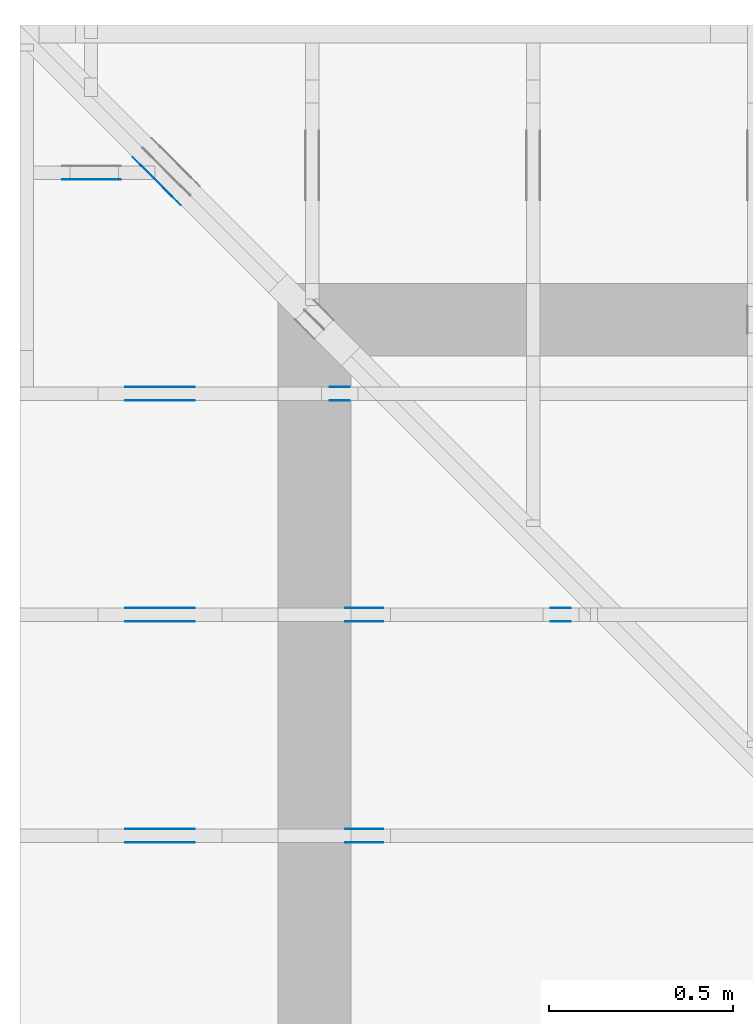
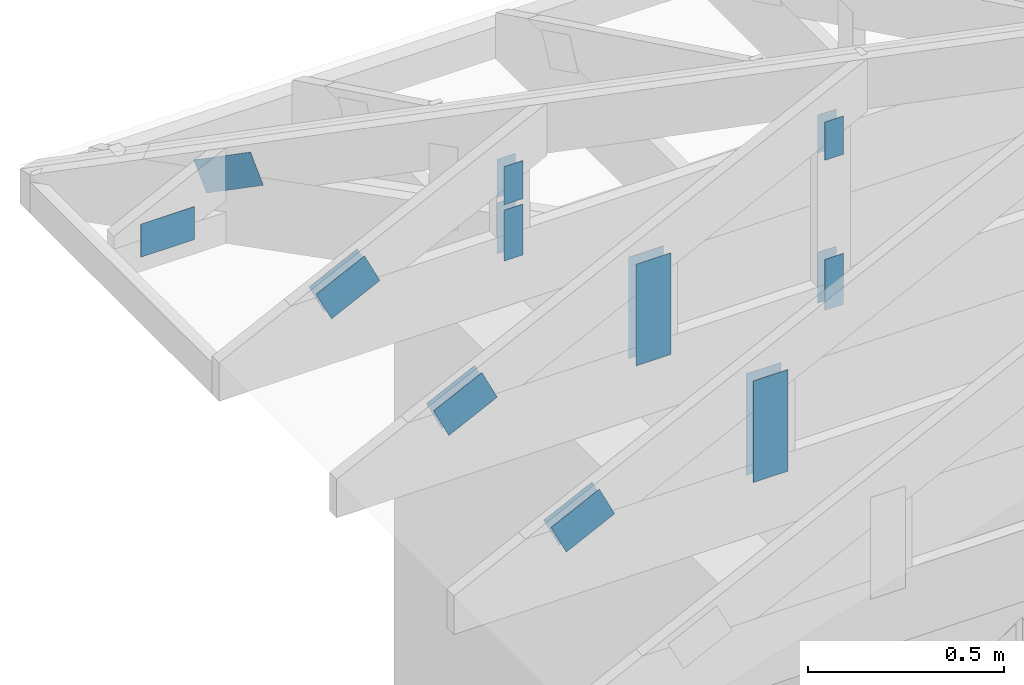
# One storey, part 89 of 159: 20 plates, 5 elements without a shape of their own.
"""IFC2X3 building model written with IfcOpenShell, lengths in millimetres."""

import ifcopenshell
import ifcopenshell.guid

model = None  # the IFC model being written
_history = None  # IfcOwnerHistory: only IFC2X3 demands one
_inside = {}  # id of a spatial element -> (the spatial element, [elements in it])
_under = {}  # id of a project, library or spatial element -> (it, [spatial elements below it])
_declared = {}  # id of a project -> (the project, [libraries it declares])
_typed = {}  # id of a type object -> (the type object, [elements of that type])
_made_of = {}  # id of a material, layer set ... -> (it, [elements and type objects made of it])


def new_model(schema):
    """Start an empty IFC model of exactly this schema.

    Asked for "IFC4X3", IfcOpenShell would pick the latest addendum, in which some entities
    have other attributes; the version numbers below select the first issue.
    IFC2X3 requires an IfcOwnerHistory on every rooted entity: one is made here for all.
    """
    global model, _history
    if schema == "IFC4X3":
        model = ifcopenshell.file(schema_version=(4, 3, 0, 0))
    else:
        model = ifcopenshell.file(schema=schema)
    _inside.clear()
    _under.clear()
    _declared.clear()
    _typed.clear()
    _made_of.clear()
    _history = None
    if model.schema == "IFC2X3":
        org = make("IfcOrganization", Name="unknown")
        user = make(
            "IfcPersonAndOrganization",
            ThePerson=make("IfcPerson", FamilyName="unknown"),
            TheOrganization=org,
        )
        app = make(
            "IfcApplication",
            ApplicationDeveloper=org,
            Version="unknown",
            ApplicationFullName="unknown",
            ApplicationIdentifier="unknown",
        )
        _history = make(
            "IfcOwnerHistory",
            OwningUser=user,
            OwningApplication=app,
            ChangeAction="ADDED",
            CreationDate=0,
        )
    return model


def make(cls, **values):
    """One entity of the class cls with the attributes given. An attribute that is None is left unset."""
    return model.create_entity(
        cls, **{name: value for name, value in values.items() if value is not None}
    )


def rooted(cls, **values):
    """An entity with a GlobalId (a new one), such as an element, a storey or a relation."""
    return make(cls, GlobalId=ifcopenshell.guid.new(), OwnerHistory=_history, **values)


def si_unit(unit_type, name, prefix=None):
    """IfcSIUnit, for example si_unit("LENGTHUNIT", "METRE", prefix="MILLI")."""
    return make("IfcSIUnit", UnitType=unit_type, Prefix=prefix, Name=name)


def assignment(units):
    """IfcUnitAssignment: the units of a project."""
    return None if units is None else make("IfcUnitAssignment", Units=units)


def point(xyz):
    """IfcCartesianPoint."""
    return None if xyz is None else make("IfcCartesianPoint", Coordinates=xyz)


def direction(xyz):
    """IfcDirection."""
    return None if xyz is None else make("IfcDirection", DirectionRatios=xyz)


def frame(location, z_axis=None, x_axis=None):
    """IfcAxis2Placement3D, a coordinate frame: its origin and axes. An axis left out is left unset."""
    return make(
        "IfcAxis2Placement3D",
        Location=point(location),
        Axis=direction(z_axis),
        RefDirection=direction(x_axis),
    )


def frame_2d(location, x_axis=None):
    """IfcAxis2Placement2D, a coordinate frame in the plane: its origin and x axis."""
    return make(
        "IfcAxis2Placement2D", Location=point(location), RefDirection=direction(x_axis)
    )


def origin():
    """The frame at (0, 0, 0) with its axes left unset."""
    return frame((0.0, 0.0, 0.0))


def origin_with_axes():
    """The frame at (0, 0, 0) with the z axis (0, 0, 1) and the x axis (1, 0, 0) written out."""
    return frame((0.0, 0.0, 0.0), z_axis=(0.0, 0.0, 1.0), x_axis=(1.0, 0.0, 0.0))


def origin_2d():
    """The frame at (0, 0) in the plane with its x axis left unset."""
    return frame_2d((0.0, 0.0))


def place(relative_to, where):
    """IfcLocalPlacement: puts the frame where relative to a parent placement (None: the world)."""
    return make(
        "IfcLocalPlacement", PlacementRelTo=relative_to, RelativePlacement=where
    )


def context(
    kind, dimensions, precision=None, world=None, true_north=None, identifier=None
):
    """IfcGeometricRepresentationContext, for example the 3D "Model" context."""
    return make(
        "IfcGeometricRepresentationContext",
        ContextIdentifier=identifier,
        ContextType=kind,
        CoordinateSpaceDimension=dimensions,
        Precision=precision,
        WorldCoordinateSystem=world,
        TrueNorth=true_north,
    )


def project(units=None, contexts=None):
    """IfcProject with its units and contexts."""
    return rooted(
        "IfcProject",
        Name="project",
        RepresentationContexts=contexts,
        UnitsInContext=assignment(units),
    )


def spatial(cls, under=None, at=None, **own):
    """A site, building, storey or space (cls), placed at a placement, below another one or the project."""
    s = rooted(cls, ObjectPlacement=at, **own)
    if under is not None:
        _under.setdefault(under.id(), (under, []))[1].append(s)
    return s


def faces_of(points, faces, orient=None, outer=None):
    """IfcFace entities. A face is a list of loops; a loop is a list of indices into points, from 0.

    orient and outer hold one flag for each loop. By default every Orientation is true, the
    first loop of a face is its IfcFaceOuterBound and the others are IfcFaceBound.
    """
    made = []
    for i, loops in enumerate(faces):
        bounds = []
        for j, loop in enumerate(loops):
            is_outer = j == 0 if outer is None else outer[i][j]
            bounds.append(
                make(
                    "IfcFaceOuterBound" if is_outer else "IfcFaceBound",
                    Bound=make("IfcPolyLoop", Polygon=[points[k] for k in loop]),
                    Orientation=True if orient is None else orient[i][j],
                )
            )
        made.append(make("IfcFace", Bounds=bounds))
    return made


def faceted_brep(points, faces, orient=None, outer=None, voids=None):
    """IfcFacetedBrep: a solid bounded by flat faces; with voids (closed shells), ...WithVoids."""
    shared = [point(p) for p in points]
    hull = make("IfcClosedShell", CfsFaces=faces_of(shared, faces, orient, outer))
    if voids is None:
        return make("IfcFacetedBrep", Outer=hull)
    return make(
        "IfcFacetedBrepWithVoids",
        Outer=hull,
        Voids=[
            make(cls, CfsFaces=faces_of(shared, fs, o, b)) for cls, fs, o, b in voids
        ],
    )


def shape(context_of_items, identifier, shape_type, items):
    """IfcShapeRepresentation: the items that make up one representation, for example the "Body"."""
    return make(
        "IfcShapeRepresentation",
        ContextOfItems=context_of_items,
        RepresentationIdentifier=identifier,
        RepresentationType=shape_type,
        Items=items,
    )


def made_of(thing, what):
    """Note that an element or type object is made of a material, layer set ...; save() writes the relation."""
    if what is not None:
        _made_of.setdefault(what.id(), (what, []))[1].append(thing)
    return thing


def element(
    cls,
    number,
    at=None,
    inside=None,
    cuts=None,
    type_object=None,
    material=None,
    context=None,
    identifier="Body",
    shape_type=None,
    held_by="IfcProductDefinitionShape",
    body=None,
    shapes=None,
    **own,
):
    """One element of the class cls, such as IfcWall. Its Tag is "e" and its number.

    at: its placement. inside: the storey or other place that contains it. cuts: it is an
    opening in that element (IfcRelVoidsElement). A single representation is given by context,
    identifier, shape_type and body (its items); several are given by shapes. held_by: the class
    of the entity that holds the representations. save() writes the other relations.
    """
    e = rooted(cls, Tag="e%d" % number, ObjectPlacement=at, **own)
    if body is not None:
        shapes = [shape(context, identifier, shape_type, body)]
    if shapes is not None:
        e.Representation = make(held_by, Representations=shapes)
    if inside is not None:
        _inside.setdefault(inside.id(), (inside, []))[1].append(e)
    if cuts is not None:
        rooted(
            "IfcRelVoidsElement", RelatingBuildingElement=cuts, RelatedOpeningElement=e
        )
    if type_object is not None:
        _typed.setdefault(type_object.id(), (type_object, []))[1].append(e)
    return made_of(e, material)


def aggregate(whole, parts):
    """IfcRelAggregates: a whole, such as a stair, and the parts it consists of."""
    return rooted("IfcRelAggregates", RelatingObject=whole, RelatedObjects=parts)


def save(model, path):
    """Write the relations noted so far, then the file.

    IfcRelAggregates (storeys below a building ...), IfcRelContainedInSpatialStructure (elements
    in a storey), IfcRelDefinesByType, IfcRelAssociatesMaterial and IfcRelDeclares: one each for
    every whole, place, type object, material and project.
    """
    for whole, parts in _under.values():
        aggregate(whole, parts)
    for where, things in _inside.values():
        rooted(
            "IfcRelContainedInSpatialStructure",
            RelatedElements=things,
            RelatingStructure=where,
        )
    for kind, things in _typed.values():
        rooted("IfcRelDefinesByType", RelatedObjects=things, RelatingType=kind)
    for what, things in _made_of.values():
        rooted("IfcRelAssociatesMaterial", RelatedObjects=things, RelatingMaterial=what)
    for by, libraries in _declared.values():
        rooted("IfcRelDeclares", RelatingContext=by, RelatedDefinitions=libraries)
    model.write(path)


model = new_model("IFC2X3")

# Units and contexts
model_context = context("Model", 3, precision=1e-05, world=origin())
plan_context = context("Plan", 2, precision=1e-05, world=origin_2d())
ifc_project = project(units=[si_unit("LENGTHUNIT", "METRE", prefix="MILLI"), si_unit("AREAUNIT", "SQUARE_METRE"), si_unit("VOLUMEUNIT", "CUBIC_METRE"), si_unit("SOLIDANGLEUNIT", "STERADIAN"), si_unit("PLANEANGLEUNIT", "RADIAN"), si_unit("MASSUNIT", "GRAM"), si_unit("TIMEUNIT", "SECOND"), si_unit("THERMODYNAMICTEMPERATUREUNIT", "DEGREE_CELSIUS"), si_unit("LUMINOUSINTENSITYUNIT", "LUMEN")], contexts=[model_context, plan_context])

# Site, building, storey
site_placement = place(None, origin_with_axes())
site = spatial("IfcSite", under=ifc_project, at=site_placement, CompositionType="ELEMENT")
building_placement = place(site_placement, origin_with_axes())
building = spatial("IfcBuilding", under=site, at=building_placement, Name="Plan 1", CompositionType="ELEMENT")
storey_placement = place(building_placement, origin_with_axes())
storey = spatial("IfcBuildingStorey", under=building, at=storey_placement, Name="Etasje 1", CompositionType="ELEMENT", Elevation=0.0)

# Assembly, plate
assembly_1_placement = place(storey_placement, frame((-664.000000000003, 9281.993668449246, 1.1021457184401395e-15), z_axis=(0.0, -1.0, 6.123031769111886e-17), x_axis=(1.0, 0.0, 0.0)))
assembly_1 = element("IfcElementAssembly", 1, at=assembly_1_placement, inside=storey, Name="S9 (107)", AssemblyPlace="FACTORY", PredefinedType="TRUSS")
plate_1_placement = place(assembly_1_placement, frame((237.78413391113284, 148.90464782714844, 0.0), z_axis=(0.0, 0.0, 1.0), x_axis=(-1.0, 1.2246063538223773e-16, 0.0)))
plate_1 = element("IfcPlate", 2, at=plate_1_placement, Name="GNT100S 103x159", context=model_context, shape_type="Brep", body=[
    faceted_brep([(159.0, 103.0, 1.0), (0.0, 103.0, 1.0), (2.842170943040401e-14, 0.0, 1.0), (159.0, 0.0, 1.0), (0.0, 103.0, 0.0), (159.0, 103.0, 1.9471241025775798e-14), (159.0, 2.842170943040401e-14, 1.9471241025775798e-14), (2.842170943040401e-14, 2.842170943040401e-14, 3.4805405954966126e-30), (159.00000085986846, 8.447997602500227e-14, 1.7883454204442307e-30), (159.00000085986846, 8.454120634269339e-14, 1.0), (8.59868492852911e-07, 1.1374806788135708e-13, 1.0), (8.59868492852911e-07, 1.1368683756366597e-13, 9.671333203439804e-39), (159.00000085986846, 103.00000000000011, 0.0), (159.00000085986846, 103.00000000000011, 1.0), (159.00000085986846, 1.1368683772161603e-13, 1.0), (159.00000085986846, 1.1368683772161603e-13, 0.0), (8.598684644312016e-07, 103.00000000000011, 0.0), (8.598684644312016e-07, 103.00000000000011, 1.0), (159.00000085986846, 103.0000000000001, 1.0), (159.00000085986846, 103.0000000000001, -7.888609052210118e-31), (8.59868492852911e-07, 1.1368683772161602e-13, 0.0), (8.598684929141413e-07, 1.1368683772161602e-13, 1.0), (8.598685055275868e-07, 103.00000000000011, 1.0), (8.598685054663564e-07, 103.00000000000011, -2.512595570956075e-30)], [[[0, 1, 2, 3]], [[4, 5, 6, 7]], [[8, 9, 10, 11]], [[12, 13, 14, 15]], [[16, 17, 18, 19]], [[20, 21, 22, 23]]]),
])
aggregate(assembly_1, [plate_1])

# Assembly, plates
assembly_2_placement = place(storey_placement, frame((-700.000000000007, 8681.993668449246, 1.1021457184401395e-15), z_axis=(0.0, -1.0, 6.123031769111886e-17), x_axis=(1.0, 0.0, 0.0)))
assembly_2 = element("IfcElementAssembly", 3, at=assembly_2_placement, inside=storey, Name="S8 (16)", AssemblyPlace="FACTORY", PredefinedType="TRUSS")
plate_2_placement = place(assembly_2_placement, frame((331.1100183702398, 141.86159042510408, 0.0), z_axis=(0.0, 0.0, 1.0), x_axis=(0.898794046299167, 0.4383711467890774, 0.0)))
plate_2 = element("IfcPlate", 4, at=plate_2_placement, Name="GNT100S 103x159", context=model_context, shape_type="Brep", body=[
    faceted_brep([(158.99998918476712, 103.00001264929412, 1.0), (1.0551442699124891e-05, 103.00001264929412, 1.0), (3.1694610242993804e-06, 1.220379553501516e-05, 1.0), (159.00000923180295, 1.220379553501516e-05, 1.0), (1.0551442699124891e-05, 103.00001264929412, 1.2921363771341076e-21), (158.99998918476712, 103.00001264929412, 1.947123970133551e-14), (159.00000923180295, 0.0, 1.9471242156308252e-14), (3.1694610242993804e-06, 0.0, 3.8813421085494012e-22), (159.00000000000006, 1.1149114128908619e-05, 4.8075085841285717e-32), (159.00000000000006, 1.114911412896985e-05, 1.0), (5.684341886080801e-14, 1.1149114158176711e-05, 1.0), (5.684341886080801e-14, 1.114911415811548e-05, 0.0), (159.00000000000006, 103.00001114911416, 0.0), (159.00000000000006, 103.00001114911416, 1.0), (159.00000000000006, 1.1149114129693771e-05, 1.0), (159.00000000000006, 1.1149114129693771e-05, 0.0), (0.0, 103.00001114911416, 0.0), (-3.7491518045553436e-33, 103.00001114911416, 1.0), (159.00000000000006, 103.00001114911414, 1.0), (159.00000000000006, 103.00001114911414, -7.888609052210118e-31), (5.68434214278835e-14, 1.114911415811548e-05, -1.5718284790124237e-37), (5.690465174557462e-14, 1.114911415811548e-05, 1.0), (2.3776908575388665e-14, 103.00001114911416, 1.0), (2.3715678257697546e-14, 103.00001114911416, -1.4521185139791808e-30)], [[[0, 1, 2, 3]], [[4, 5, 6, 7]], [[8, 9, 10, 11]], [[12, 13, 14, 15]], [[16, 17, 18, 19]], [[20, 21, 22, 23]]]),
])
plate_3_placement = place(assembly_2_placement, frame((331.1100183702398, 141.86159042510408, -37.00000000000001), z_axis=(0.0, 0.0, 1.0), x_axis=(0.898794046299167, 0.4383711467890774, 0.0)))
plate_3 = element("IfcPlate", 5, at=plate_3_placement, Name="GNT100S 103x159", context=model_context, shape_type="Brep", body=[
    faceted_brep([(158.99998918476712, 103.00001264929412, 1.0), (1.0551442699124891e-05, 103.00001264929412, 1.0), (3.1694610242993804e-06, 1.220379553501516e-05, 1.0), (159.00000923180295, 1.220379553501516e-05, 1.0), (1.0551442699124891e-05, 103.00001264929412, 1.2921363771341076e-21), (158.99998918476712, 103.00001264929412, 1.947123970133551e-14), (159.00000923180295, 0.0, 1.9471242156308252e-14), (3.1694610242993804e-06, 0.0, 3.8813421085494012e-22), (159.00000000000006, 1.1149114128908619e-05, 4.8075085841285717e-32), (159.00000000000006, 1.114911412896985e-05, 1.0), (5.684341886080801e-14, 1.1149114158176711e-05, 1.0), (5.684341886080801e-14, 1.114911415811548e-05, 0.0), (159.00000000000006, 103.00001114911416, 0.0), (159.00000000000006, 103.00001114911416, 1.0), (159.00000000000006, 1.1149114129693771e-05, 1.0), (159.00000000000006, 1.1149114129693771e-05, 0.0), (0.0, 103.00001114911416, 0.0), (-3.7491518045553436e-33, 103.00001114911416, 1.0), (159.00000000000006, 103.00001114911414, 1.0), (159.00000000000006, 103.00001114911414, -7.888609052210118e-31), (5.68434214278835e-14, 1.114911415811548e-05, -1.5718284790124237e-37), (5.690465174557462e-14, 1.114911415811548e-05, 1.0), (2.3776908575388665e-14, 103.00001114911416, 1.0), (2.3715678257697546e-14, 103.00001114911416, -1.4521185139791808e-30)], [[[0, 1, 2, 3]], [[4, 5, 6, 7]], [[8, 9, 10, 11]], [[12, 13, 14, 15]], [[16, 17, 18, 19]], [[20, 21, 22, 23]]]),
])
plate_4_placement = place(assembly_2_placement, frame((840.5946433071217, 438.23297119140625, 0.0), z_axis=(0.0, 0.0, 1.0), x_axis=(6.123031769111886e-17, -1.0, 0.0)))
plate_4 = element("IfcPlate", 6, at=plate_4_placement, Name="GNT100S 55x119", context=model_context, shape_type="Brep", body=[
    faceted_brep([(119.0, 55.000022220222036, 1.0), (0.0, 55.000022220222036, 1.0), (0.0, 2.2220222035684856e-05, 1.0), (119.0, 2.2220222035684856e-05, 1.0), (0.0, 55.000022220222036, 0.0), (119.0, 55.000022220222036, 1.457281561048629e-14), (119.0, 2.2220222035684856e-05, 1.457281561048629e-14), (0.0, 2.2220222035684856e-05, 0.0), (119.00001088225764, -2.1859225414701712e-14, 1.3384473166239653e-30), (119.00001088225764, -2.1797995097010593e-14, 1.0), (1.088225764078743e-05, 6.122831871884123e-17, 1.0), (1.088225764078743e-05, -1.99897227762606e-21, 1.223977076147831e-37), (119.00001088225764, 55.0, 0.0), (119.00001088225764, 55.0, 1.0), (119.00001088225764, 0.0, 1.0), (119.00001088225764, 0.0, 0.0), (1.088225764078743e-05, 55.0, 0.0), (1.088225764078743e-05, 55.0, 1.0), (119.00001088225764, 54.99999999999999, 1.0), (119.00001088225764, 54.99999999999999, -3.944304526105059e-31), (1.088225764078743e-05, 0.0, 0.0), (1.088225764084866e-05, -7.498303609110687e-33, 1.0), (1.0882257647583995e-05, 55.0, 1.0), (1.0882257647522764e-05, 55.0, -4.124066764605687e-31)], [[[0, 1, 2, 3]], [[4, 5, 6, 7]], [[8, 9, 10, 11]], [[12, 13, 14, 15]], [[16, 17, 18, 19]], [[20, 21, 22, 23]]]),
])
plate_5_placement = place(assembly_2_placement, frame((840.5946433071217, 438.23297119140625, -37.0), z_axis=(0.0, 0.0, 1.0), x_axis=(6.123031769111886e-17, -1.0, 0.0)))
plate_5 = element("IfcPlate", 7, at=plate_5_placement, Name="GNT100S 55x119", context=model_context, shape_type="Brep", body=[
    faceted_brep([(119.0, 55.000022220222036, 1.0), (0.0, 55.000022220222036, 1.0), (0.0, 2.2220222035684856e-05, 1.0), (119.0, 2.2220222035684856e-05, 1.0), (0.0, 55.000022220222036, 0.0), (119.0, 55.000022220222036, 1.457281561048629e-14), (119.0, 2.2220222035684856e-05, 1.457281561048629e-14), (0.0, 2.2220222035684856e-05, 0.0), (119.00001088225764, -2.1859225414701712e-14, 1.3384473166239653e-30), (119.00001088225764, -2.1797995097010593e-14, 1.0), (1.088225764078743e-05, 6.122831871884123e-17, 1.0), (1.088225764078743e-05, -1.99897227762606e-21, 1.223977076147831e-37), (119.00001088225764, 55.0, 0.0), (119.00001088225764, 55.0, 1.0), (119.00001088225764, 0.0, 1.0), (119.00001088225764, 0.0, 0.0), (1.088225764078743e-05, 55.0, 0.0), (1.088225764078743e-05, 55.0, 1.0), (119.00001088225764, 54.99999999999999, 1.0), (119.00001088225764, 54.99999999999999, -3.944304526105059e-31), (1.088225764078743e-05, 0.0, 0.0), (1.088225764084866e-05, -7.498303609110687e-33, 1.0), (1.0882257647583995e-05, 55.0, 1.0), (1.0882257647522764e-05, 55.0, -4.124066764605687e-31)], [[[0, 1, 2, 3]], [[4, 5, 6, 7]], [[8, 9, 10, 11]], [[12, 13, 14, 15]], [[16, 17, 18, 19]], [[20, 21, 22, 23]]]),
])
plate_6_placement = place(assembly_2_placement, frame((895.5946655273438, 143.5, 0.0), z_axis=(0.0, 0.0, 1.0), x_axis=(6.123031769111886e-17, 1.0, 0.0)))
plate_6 = element("IfcPlate", 8, at=plate_6_placement, Name="GNT100S 55x159", context=model_context, shape_type="Brep", body=[
    faceted_brep([(159.0, 55.0, 1.0), (0.0, 55.0, 1.0), (0.0, 0.0, 1.0), (159.0, 0.0, 1.0), (0.0, 55.0, 0.0), (159.0, 55.0, 1.9471241025775798e-14), (159.0, 0.0, 1.9471241025775798e-14), (0.0, 0.0, 0.0), (159.00000000069178, 2.22201997238578e-05, 1.788345383589592e-30), (159.00000000069178, 2.222019972391903e-05, 1.0), (6.918128292454639e-10, 2.2220199753125893e-05, 1.0), (6.918128292454639e-10, 2.2220199753064662e-05, 0.0), (159.00000000069178, 55.00002222019975, 0.0), (159.00000000069178, 55.00002222019975, 1.0), (159.00000000069178, 2.2220199753064662e-05, 1.0), (159.00000000069178, 2.2220199753064662e-05, 0.0), (6.918128292454639e-10, 55.00002222019975, 0.0), (6.918128292454639e-10, 55.00002222019975, 1.0), (159.00000000069178, 55.000022220199746, 1.0), (159.00000000069178, 55.000022220199746, -7.888609052210118e-31), (6.918128292481851e-10, 2.2220199753064662e-05, -1.6661254890463556e-37), (6.918128904785028e-10, 2.2220199753064662e-05, 1.0), (6.918196258134488e-10, 55.00002222019975, 1.0), (6.918195645831311e-10, 55.00002222019975, -4.124068651136367e-31)], [[[0, 1, 2, 3]], [[4, 5, 6, 7]], [[8, 9, 10, 11]], [[12, 13, 14, 15]], [[16, 17, 18, 19]], [[20, 21, 22, 23]]]),
])
plate_7_placement = place(assembly_2_placement, frame((895.5946655273438, 143.5, -37.0), z_axis=(0.0, 0.0, 1.0), x_axis=(6.123031769111886e-17, 1.0, 0.0)))
plate_7 = element("IfcPlate", 9, at=plate_7_placement, Name="GNT100S 55x159", context=model_context, shape_type="Brep", body=[
    faceted_brep([(159.0, 55.0, 1.0), (0.0, 55.0, 1.0), (0.0, 0.0, 1.0), (159.0, 0.0, 1.0), (0.0, 55.0, 0.0), (159.0, 55.0, 1.9471241025775798e-14), (159.0, 0.0, 1.9471241025775798e-14), (0.0, 0.0, 0.0), (159.00000000069178, 2.22201997238578e-05, 1.788345383589592e-30), (159.00000000069178, 2.222019972391903e-05, 1.0), (6.918128292454639e-10, 2.2220199753125893e-05, 1.0), (6.918128292454639e-10, 2.2220199753064662e-05, 0.0), (159.00000000069178, 55.00002222019975, 0.0), (159.00000000069178, 55.00002222019975, 1.0), (159.00000000069178, 2.2220199753064662e-05, 1.0), (159.00000000069178, 2.2220199753064662e-05, 0.0), (6.918128292454639e-10, 55.00002222019975, 0.0), (6.918128292454639e-10, 55.00002222019975, 1.0), (159.00000000069178, 55.000022220199746, 1.0), (159.00000000069178, 55.000022220199746, -7.888609052210118e-31), (6.918128292481851e-10, 2.2220199753064662e-05, -1.6661254890463556e-37), (6.918128904785028e-10, 2.2220199753064662e-05, 1.0), (6.918196258134488e-10, 55.00002222019975, 1.0), (6.918195645831311e-10, 55.00002222019975, -4.124068651136367e-31)], [[[0, 1, 2, 3]], [[4, 5, 6, 7]], [[8, 9, 10, 11]], [[12, 13, 14, 15]], [[16, 17, 18, 19]], [[20, 21, 22, 23]]]),
])
aggregate(assembly_2, [plate_2, plate_3, plate_4, plate_5, plate_6, plate_7])

assembly_3_placement = place(storey_placement, frame((-700.000000000007, 8081.993668449246, 1.1021457184401395e-15), z_axis=(0.0, -1.0, 6.123031769111886e-17), x_axis=(1.0, 0.0, 0.0)))
assembly_3 = element("IfcElementAssembly", 10, at=assembly_3_placement, inside=storey, Name="S7 (14)", AssemblyPlace="FACTORY", PredefinedType="TRUSS")
plate_8_placement = place(assembly_3_placement, frame((1440.5946044921875, 730.8725134480499, 0.0), z_axis=(0.0, 0.0, 1.0), x_axis=(6.123031769111886e-17, -1.0, 0.0)))
plate_8 = element("IfcPlate", 11, at=plate_8_placement, Name="GNT100S 55x119", context=model_context, shape_type="Brep", body=[
    faceted_brep([(119.00001588945611, 55.0, 1.0), (1.588945610819792e-05, 55.0, 1.0), (1.588945610819792e-05, 0.0, 1.0), (119.00001588945611, 0.0, 1.0), (1.588945610819792e-05, 55.0, 1.9458328908880954e-21), (119.00001588945611, 55.0, 1.457281755631918e-14), (119.00001588945611, 0.0, 1.457281755631918e-14), (1.588945610819792e-05, 0.0, 1.9458328908880954e-21), (119.0, 3.881493964942413e-05, 1.338447208185253e-30), (119.0, 3.881493964948536e-05, 1.0), (1.1247455413666031e-32, 3.8814939671344585e-05, 1.0), (0.0, 3.8814939671283355e-05, 0.0), (119.0, 55.00003881493967, 0.0), (119.0, 55.00003881493967, 1.0), (119.0, 3.8814939671283355e-05, 1.0), (119.0, 3.8814939671283355e-05, 0.0), (0.0, 55.00003881493967, 0.0), (-3.7491518045553436e-33, 55.00003881493967, 1.0), (119.0, 55.000038814939664, 1.0), (119.0, 55.000038814939664, -3.944304526105059e-31), (4.753302174468585e-21, 3.8814939671283355e-05, -2.9104620222459757e-37), (6.123507099329333e-17, 3.8814939671283355e-05, 1.0), (6.796570017016369e-15, 55.00003881493967, 1.0), (6.73533969932525e-15, 55.00003881493967, -4.1240698954729e-31)], [[[0, 1, 2, 3]], [[4, 5, 6, 7]], [[8, 9, 10, 11]], [[12, 13, 14, 15]], [[16, 17, 18, 19]], [[20, 21, 22, 23]]]),
])
plate_9_placement = place(assembly_3_placement, frame((1440.5946044921875, 730.8725134480499, -37.0), z_axis=(0.0, 0.0, 1.0), x_axis=(6.123031769111886e-17, -1.0, 0.0)))
plate_9 = element("IfcPlate", 12, at=plate_9_placement, Name="GNT100S 55x119", context=model_context, shape_type="Brep", body=[
    faceted_brep([(119.00001588945611, 55.0, 1.0), (1.588945610819792e-05, 55.0, 1.0), (1.588945610819792e-05, 0.0, 1.0), (119.00001588945611, 0.0, 1.0), (1.588945610819792e-05, 55.0, 1.9458328908880954e-21), (119.00001588945611, 55.0, 1.457281755631918e-14), (119.00001588945611, 0.0, 1.457281755631918e-14), (1.588945610819792e-05, 0.0, 1.9458328908880954e-21), (119.0, 3.881493964942413e-05, 1.338447208185253e-30), (119.0, 3.881493964948536e-05, 1.0), (1.1247455413666031e-32, 3.8814939671344585e-05, 1.0), (0.0, 3.8814939671283355e-05, 0.0), (119.0, 55.00003881493967, 0.0), (119.0, 55.00003881493967, 1.0), (119.0, 3.8814939671283355e-05, 1.0), (119.0, 3.8814939671283355e-05, 0.0), (0.0, 55.00003881493967, 0.0), (-3.7491518045553436e-33, 55.00003881493967, 1.0), (119.0, 55.000038814939664, 1.0), (119.0, 55.000038814939664, -3.944304526105059e-31), (4.753302174468585e-21, 3.8814939671283355e-05, -2.9104620222459757e-37), (6.123507099329333e-17, 3.8814939671283355e-05, 1.0), (6.796570017016369e-15, 55.00003881493967, 1.0), (6.73533969932525e-15, 55.00003881493967, -4.1240698954729e-31)], [[[0, 1, 2, 3]], [[4, 5, 6, 7]], [[8, 9, 10, 11]], [[12, 13, 14, 15]], [[16, 17, 18, 19]], [[20, 21, 22, 23]]]),
])
plate_10_placement = place(assembly_3_placement, frame((1495.5946433071513, 143.5, 0.0), z_axis=(0.0, 0.0, 1.0), x_axis=(6.123031769111886e-17, 1.0, 0.0)))
plate_10 = element("IfcPlate", 13, at=plate_10_placement, Name="GNT100S 55x159", context=model_context, shape_type="Brep", body=[
    faceted_brep([(159.00000000000003, 55.00003881496377, 1.0), (0.0, 55.00003881496377, 1.0), (0.0, 3.881496377289295e-05, 1.0), (159.00000000000003, 3.881496377289295e-05, 1.0), (0.0, 55.00003881496377, 0.0), (159.00000000000003, 55.00003881496377, 1.94712410257758e-14), (159.00000000000003, 3.881496377289295e-05, 1.94712410257758e-14), (0.0, 3.881496377289295e-05, 0.0), (159.0000000004168, -2.920686153874026e-14, 1.788345410777587e-30), (159.0000000004168, -2.914563122104914e-14, 1.0), (4.1680436879687477e-10, 6.123031761455567e-17, 1.0), (4.1680436879687477e-10, -7.656319174943674e-26, 4.687988554264062e-42), (159.0000000004168, 55.0, 0.0), (159.0000000004168, 55.0, 1.0), (159.0000000004168, 0.0, 1.0), (159.0000000004168, 0.0, 0.0), (4.1680436879687477e-10, 55.0, 0.0), (4.1680436879687477e-10, 55.0, 1.0), (159.0000000004168, 54.99999999999999, 1.0), (159.0000000004168, 54.99999999999999, -7.888609052210118e-31), (4.1680436879687477e-10, 0.0, 0.0), (4.1680443002719246e-10, -7.498303609110687e-33, 1.0), (4.168111653621385e-10, 55.0, 1.0), (4.168111041318208e-10, 55.0, -4.124066985010878e-31)], [[[0, 1, 2, 3]], [[4, 5, 6, 7]], [[8, 9, 10, 11]], [[12, 13, 14, 15]], [[16, 17, 18, 19]], [[20, 21, 22, 23]]]),
])
plate_11_placement = place(assembly_3_placement, frame((1495.5946433071513, 143.5, -37.0), z_axis=(0.0, 0.0, 1.0), x_axis=(6.123031769111886e-17, 1.0, 0.0)))
plate_11 = element("IfcPlate", 14, at=plate_11_placement, Name="GNT100S 55x159", context=model_context, shape_type="Brep", body=[
    faceted_brep([(159.00000000000003, 55.00003881496377, 1.0), (0.0, 55.00003881496377, 1.0), (0.0, 3.881496377289295e-05, 1.0), (159.00000000000003, 3.881496377289295e-05, 1.0), (0.0, 55.00003881496377, 0.0), (159.00000000000003, 55.00003881496377, 1.94712410257758e-14), (159.00000000000003, 3.881496377289295e-05, 1.94712410257758e-14), (0.0, 3.881496377289295e-05, 0.0), (159.0000000004168, -2.920686153874026e-14, 1.788345410777587e-30), (159.0000000004168, -2.914563122104914e-14, 1.0), (4.1680436879687477e-10, 6.123031761455567e-17, 1.0), (4.1680436879687477e-10, -7.656319174943674e-26, 4.687988554264062e-42), (159.0000000004168, 55.0, 0.0), (159.0000000004168, 55.0, 1.0), (159.0000000004168, 0.0, 1.0), (159.0000000004168, 0.0, 0.0), (4.1680436879687477e-10, 55.0, 0.0), (4.1680436879687477e-10, 55.0, 1.0), (159.0000000004168, 54.99999999999999, 1.0), (159.0000000004168, 54.99999999999999, -7.888609052210118e-31), (4.1680436879687477e-10, 0.0, 0.0), (4.1680443002719246e-10, -7.498303609110687e-33, 1.0), (4.168111653621385e-10, 55.0, 1.0), (4.168111041318208e-10, 55.0, -4.124066985010878e-31)], [[[0, 1, 2, 3]], [[4, 5, 6, 7]], [[8, 9, 10, 11]], [[12, 13, 14, 15]], [[16, 17, 18, 19]], [[20, 21, 22, 23]]]),
])
plate_12_placement = place(assembly_3_placement, frame((331.11001837023974, 141.86159042510405, 0.0), z_axis=(0.0, 0.0, 1.0), x_axis=(0.898794046299167, 0.4383711467890774, 0.0)))
plate_12 = element("IfcPlate", 15, at=plate_12_placement, Name="GNT100S 103x159", context=model_context, shape_type="Brep", body=[
    faceted_brep([(158.99998918476717, 103.00001264929412, 1.0), (1.055144275596831e-05, 103.00001264929412, 1.0), (3.1694610811427992e-06, 1.220379553501516e-05, 1.0), (159.000009231803, 1.220379553501516e-05, 1.0), (1.055144275596831e-05, 103.00001264929412, 1.2921363840951888e-21), (158.99998918476717, 103.00001264929412, 1.9471239701335515e-14), (159.000009231803, 0.0, 1.947124215630826e-14), (3.1694610811427992e-06, 0.0, 3.881342178160213e-22), (159.0000000000001, 1.11491140720652e-05, 4.8075085841285717e-32), (159.0000000000001, 1.114911407212643e-05, 1.0), (5.684341886080802e-14, 1.1149114101333292e-05, 1.0), (5.684341886080802e-14, 1.1149114101272062e-05, 0.0), (159.0000000000001, 103.0000111491141, 0.0), (159.0000000000001, 103.0000111491141, 1.0), (159.0000000000001, 1.1149114072850352e-05, 1.0), (159.0000000000001, 1.1149114072850352e-05, 0.0), (0.0, 103.0000111491141, 0.0), (-3.7491518045553436e-33, 103.0000111491141, 1.0), (159.0000000000001, 103.00001114911409, 1.0), (159.0000000000001, 103.00001114911409, -7.888609052210118e-31), (5.684342142788349e-14, 1.1149114101272062e-05, -1.5718284720059314e-37), (5.690465174557461e-14, 1.1149114101272062e-05, 1.0), (2.377690857538864e-14, 103.0000111491141, 1.0), (2.371567825769752e-14, 103.0000111491141, -1.4521185139791798e-30)], [[[0, 1, 2, 3]], [[4, 5, 6, 7]], [[8, 9, 10, 11]], [[12, 13, 14, 15]], [[16, 17, 18, 19]], [[20, 21, 22, 23]]]),
])
plate_13_placement = place(assembly_3_placement, frame((331.11001837023974, 141.86159042510405, -37.00000000000001), z_axis=(0.0, 0.0, 1.0), x_axis=(0.898794046299167, 0.4383711467890774, 0.0)))
plate_13 = element("IfcPlate", 16, at=plate_13_placement, Name="GNT100S 103x159", context=model_context, shape_type="Brep", body=[
    faceted_brep([(158.99998918476717, 103.00001264929412, 1.0), (1.055144275596831e-05, 103.00001264929412, 1.0), (3.1694610811427992e-06, 1.220379553501516e-05, 1.0), (159.000009231803, 1.220379553501516e-05, 1.0), (1.055144275596831e-05, 103.00001264929412, 1.2921363840951888e-21), (158.99998918476717, 103.00001264929412, 1.9471239701335515e-14), (159.000009231803, 0.0, 1.947124215630826e-14), (3.1694610811427992e-06, 0.0, 3.881342178160213e-22), (159.0000000000001, 1.11491140720652e-05, 4.8075085841285717e-32), (159.0000000000001, 1.114911407212643e-05, 1.0), (5.684341886080802e-14, 1.1149114101333292e-05, 1.0), (5.684341886080802e-14, 1.1149114101272062e-05, 0.0), (159.0000000000001, 103.0000111491141, 0.0), (159.0000000000001, 103.0000111491141, 1.0), (159.0000000000001, 1.1149114072850352e-05, 1.0), (159.0000000000001, 1.1149114072850352e-05, 0.0), (0.0, 103.0000111491141, 0.0), (-3.7491518045553436e-33, 103.0000111491141, 1.0), (159.0000000000001, 103.00001114911409, 1.0), (159.0000000000001, 103.00001114911409, -7.888609052210118e-31), (5.684342142788349e-14, 1.1149114101272062e-05, -1.5718284720059314e-37), (5.690465174557461e-14, 1.1149114101272062e-05, 1.0), (2.377690857538864e-14, 103.0000111491141, 1.0), (2.371567825769752e-14, 103.0000111491141, -1.4521185139791798e-30)], [[[0, 1, 2, 3]], [[4, 5, 6, 7]], [[8, 9, 10, 11]], [[12, 13, 14, 15]], [[16, 17, 18, 19]], [[20, 21, 22, 23]]]),
])
plate_14_placement = place(assembly_3_placement, frame((986.0125131984591, 165.43966674804688, 0.0), z_axis=(0.0, 0.0, 1.0), x_axis=(6.123031769111886e-17, 1.0, 0.0)))
plate_14 = element("IfcPlate", 17, at=plate_14_placement, Name="GNT100S 103x317", context=model_context, shape_type="Brep", body=[
    faceted_brep([(317.0, 103.0000009914279, 1.0), (0.0, 103.0000009914279, 1.0), (0.0, 9.914278962241951e-07, 1.0), (317.0, 9.914278962241951e-07, 1.0), (0.0, 103.0000009914279, 0.0), (317.0, 103.0000009914279, 3.882002141616936e-14), (317.0, 9.914278962241951e-07, 3.882002141616936e-14), (0.0, 9.914278962241951e-07, 0.0), (317.0000058634539, -5.823003320131748e-14, 3.565443432081068e-30), (317.0000058634539, -5.816880288362636e-14, 1.0), (5.8634539072954794e-06, 6.122924062768232e-17, 1.0), (5.8634539072954794e-06, -1.0770634365328032e-21, 6.594893639239178e-38), (317.0000058634539, 103.0, 0.0), (317.0000058634539, 103.0, 1.0), (317.0000058634539, 0.0, 1.0), (317.0000058634539, 0.0, 0.0), (5.8634539072954794e-06, 103.0, 0.0), (5.8634539072954794e-06, 103.0, 1.0), (317.0000058634539, 102.99999999999999, 1.0), (317.0000058634539, 102.99999999999999, -1.5777218104420236e-30), (5.8634539072954794e-06, 0.0, 0.0), (5.86345390735671e-06, -7.498303609110687e-33, 1.0), (5.863453919970155e-06, 103.0, 1.0), (5.863453919908925e-06, 103.0, -7.723252732077687e-31)], [[[0, 1, 2, 3]], [[4, 5, 6, 7]], [[8, 9, 10, 11]], [[12, 13, 14, 15]], [[16, 17, 18, 19]], [[20, 21, 22, 23]]]),
])
plate_15_placement = place(assembly_3_placement, frame((986.0125131984591, 165.43966674804688, -37.0), z_axis=(0.0, 0.0, 1.0), x_axis=(6.123031769111886e-17, 1.0, 0.0)))
plate_15 = element("IfcPlate", 18, at=plate_15_placement, Name="GNT100S 103x317", context=model_context, shape_type="Brep", body=[
    faceted_brep([(317.0, 103.0000009914279, 1.0), (0.0, 103.0000009914279, 1.0), (0.0, 9.914278962241951e-07, 1.0), (317.0, 9.914278962241951e-07, 1.0), (0.0, 103.0000009914279, 0.0), (317.0, 103.0000009914279, 3.882002141616936e-14), (317.0, 9.914278962241951e-07, 3.882002141616936e-14), (0.0, 9.914278962241951e-07, 0.0), (317.0000058634539, -5.823003320131748e-14, 3.565443432081068e-30), (317.0000058634539, -5.816880288362636e-14, 1.0), (5.8634539072954794e-06, 6.122924062768232e-17, 1.0), (5.8634539072954794e-06, -1.0770634365328032e-21, 6.594893639239178e-38), (317.0000058634539, 103.0, 0.0), (317.0000058634539, 103.0, 1.0), (317.0000058634539, 0.0, 1.0), (317.0000058634539, 0.0, 0.0), (5.8634539072954794e-06, 103.0, 0.0), (5.8634539072954794e-06, 103.0, 1.0), (317.0000058634539, 102.99999999999999, 1.0), (317.0000058634539, 102.99999999999999, -1.5777218104420236e-30), (5.8634539072954794e-06, 0.0, 0.0), (5.86345390735671e-06, -7.498303609110687e-33, 1.0), (5.863453919970155e-06, 103.0, 1.0), (5.863453919908925e-06, 103.0, -7.723252732077687e-31)], [[[0, 1, 2, 3]], [[4, 5, 6, 7]], [[8, 9, 10, 11]], [[12, 13, 14, 15]], [[16, 17, 18, 19]], [[20, 21, 22, 23]]]),
])
aggregate(assembly_3, [plate_8, plate_9, plate_10, plate_11, plate_12, plate_13, plate_14, plate_15])

assembly_4_placement = place(storey_placement, frame((-700.000000000007, 7481.993668449246, 1.1021457184401395e-15), z_axis=(0.0, -1.0, 6.123031769111886e-17), x_axis=(1.0, 0.0, 0.0)))
assembly_4 = element("IfcElementAssembly", 19, at=assembly_4_placement, inside=storey, Name="S6 (12)", AssemblyPlace="FACTORY", PredefinedType="TRUSS")
plate_16_placement = place(assembly_4_placement, frame((331.1100183702398, 141.86159042510408, 0.0), z_axis=(0.0, 0.0, 1.0), x_axis=(0.898794046299167, 0.4383711467890774, 0.0)))
plate_16 = element("IfcPlate", 20, at=plate_16_placement, Name="GNT100S 103x159", context=model_context, shape_type="Brep", body=[
    faceted_brep([(158.99998918476712, 103.00001264929412, 1.0), (1.0551442699124891e-05, 103.00001264929412, 1.0), (3.1694610242993804e-06, 1.220379553501516e-05, 1.0), (159.00000923180295, 1.220379553501516e-05, 1.0), (1.0551442699124891e-05, 103.00001264929412, 1.2921363771341076e-21), (158.99998918476712, 103.00001264929412, 1.947123970133551e-14), (159.00000923180295, 0.0, 1.9471242156308252e-14), (3.1694610242993804e-06, 0.0, 3.8813421085494012e-22), (159.00000000000006, 1.1149114029432636e-05, 2.6584805324637452e-30), (159.00000000000006, 1.1149114029493866e-05, 1.0), (5.684341886080802e-14, 1.1149114058700728e-05, 1.0), (5.684341886080802e-14, 1.1149114058639498e-05, 0.0), (159.00000000000006, 103.0000111491141, 0.0), (159.00000000000006, 103.0000111491141, 1.0), (159.00000000000006, 1.1149114072850352e-05, 1.0), (159.00000000000006, 1.1149114072850352e-05, 0.0), (0.0, 103.00001114911407, 0.0), (0.0, 103.00001114911407, 1.0), (159.00000000000006, 103.0000111491141, 1.0), (159.00000000000006, 103.0000111491141, 0.0), (5.684342142788349e-14, 1.1149114058639498e-05, -1.5718284720059314e-37), (5.690465174557461e-14, 1.1149114058639498e-05, 1.0), (2.377690857538864e-14, 103.00001114911407, 1.0), (2.371567825769752e-14, 103.00001114911407, -1.4521185139791798e-30)], [[[0, 1, 2, 3]], [[4, 5, 6, 7]], [[8, 9, 10, 11]], [[12, 13, 14, 15]], [[16, 17, 18, 19]], [[20, 21, 22, 23]]]),
])
plate_17_placement = place(assembly_4_placement, frame((331.1100183702398, 141.86159042510408, -37.00000000000001), z_axis=(0.0, 0.0, 1.0), x_axis=(0.898794046299167, 0.4383711467890774, 0.0)))
plate_17 = element("IfcPlate", 21, at=plate_17_placement, Name="GNT100S 103x159", context=model_context, shape_type="Brep", body=[
    faceted_brep([(158.99998918476712, 103.00001264929412, 1.0), (1.0551442699124891e-05, 103.00001264929412, 1.0), (3.1694610242993804e-06, 1.220379553501516e-05, 1.0), (159.00000923180295, 1.220379553501516e-05, 1.0), (1.0551442699124891e-05, 103.00001264929412, 1.2921363771341076e-21), (158.99998918476712, 103.00001264929412, 1.947123970133551e-14), (159.00000923180295, 0.0, 1.9471242156308252e-14), (3.1694610242993804e-06, 0.0, 3.8813421085494012e-22), (159.00000000000006, 1.1149114029432636e-05, 2.6584805324637452e-30), (159.00000000000006, 1.1149114029493866e-05, 1.0), (5.684341886080802e-14, 1.1149114058700728e-05, 1.0), (5.684341886080802e-14, 1.1149114058639498e-05, 0.0), (159.00000000000006, 103.0000111491141, 0.0), (159.00000000000006, 103.0000111491141, 1.0), (159.00000000000006, 1.1149114072850352e-05, 1.0), (159.00000000000006, 1.1149114072850352e-05, 0.0), (0.0, 103.00001114911407, 0.0), (0.0, 103.00001114911407, 1.0), (159.00000000000006, 103.0000111491141, 1.0), (159.00000000000006, 103.0000111491141, 0.0), (5.684342142788349e-14, 1.1149114058639498e-05, -1.5718284720059314e-37), (5.690465174557461e-14, 1.1149114058639498e-05, 1.0), (2.377690857538864e-14, 103.00001114911407, 1.0), (2.371567825769752e-14, 103.00001114911407, -1.4521185139791798e-30)], [[[0, 1, 2, 3]], [[4, 5, 6, 7]], [[8, 9, 10, 11]], [[12, 13, 14, 15]], [[16, 17, 18, 19]], [[20, 21, 22, 23]]]),
])
plate_18_placement = place(assembly_4_placement, frame((986.0125131973784, 165.43966674804688, 0.0), z_axis=(0.0, 0.0, 1.0), x_axis=(6.123031769111886e-17, 1.0, 0.0)))
plate_18 = element("IfcPlate", 22, at=plate_18_placement, Name="GNT100S 103x317", context=model_context, shape_type="Brep", body=[
    faceted_brep([(317.0, 103.00000099034719, 1.0), (0.0, 103.00000099034719, 1.0), (0.0, 9.903471891448135e-07, 1.0), (317.0, 9.903471891448135e-07, 1.0), (0.0, 103.00000099034719, 0.0), (317.0, 103.00000099034719, 3.882002141616936e-14), (317.0, 9.903471891448135e-07, 3.882002141616936e-14), (0.0, 9.903471891448135e-07, 0.0), (317.00000586342895, -5.823003320131289e-14, 3.565443432080788e-30), (317.00000586342895, -5.816880288362177e-14, 1.0), (5.8634289530345995e-06, 6.12292406322662e-17, 1.0), (5.8634289530345995e-06, -1.077058852660839e-21, 6.594865572045515e-38), (317.00000586342895, 103.0, 0.0), (317.00000586342895, 103.0, 1.0), (317.00000586342895, 0.0, 1.0), (317.00000586342895, 0.0, 0.0), (5.8634289530345995e-06, 103.0, 0.0), (5.8634289530345995e-06, 103.0, 1.0), (317.00000586342895, 102.99999999999999, 1.0), (317.00000586342895, 102.99999999999999, -1.5777218104420236e-30), (5.8634289530345995e-06, 0.0, 0.0), (5.86342895309583e-06, -7.498303609110687e-33, 1.0), (5.863428965709275e-06, 103.0, 1.0), (5.863428965648045e-06, 103.0, -7.723252732077687e-31)], [[[0, 1, 2, 3]], [[4, 5, 6, 7]], [[8, 9, 10, 11]], [[12, 13, 14, 15]], [[16, 17, 18, 19]], [[20, 21, 22, 23]]]),
])
plate_19_placement = place(assembly_4_placement, frame((986.0125131973784, 165.43966674804688, -37.0), z_axis=(0.0, 0.0, 1.0), x_axis=(6.123031769111886e-17, 1.0, 0.0)))
plate_19 = element("IfcPlate", 23, at=plate_19_placement, Name="GNT100S 103x317", context=model_context, shape_type="Brep", body=[
    faceted_brep([(317.0, 103.00000099034719, 1.0), (0.0, 103.00000099034719, 1.0), (0.0, 9.903471891448135e-07, 1.0), (317.0, 9.903471891448135e-07, 1.0), (0.0, 103.00000099034719, 0.0), (317.0, 103.00000099034719, 3.882002141616936e-14), (317.0, 9.903471891448135e-07, 3.882002141616936e-14), (0.0, 9.903471891448135e-07, 0.0), (317.00000586342895, -5.823003320131289e-14, 3.565443432080788e-30), (317.00000586342895, -5.816880288362177e-14, 1.0), (5.8634289530345995e-06, 6.12292406322662e-17, 1.0), (5.8634289530345995e-06, -1.077058852660839e-21, 6.594865572045515e-38), (317.00000586342895, 103.0, 0.0), (317.00000586342895, 103.0, 1.0), (317.00000586342895, 0.0, 1.0), (317.00000586342895, 0.0, 0.0), (5.8634289530345995e-06, 103.0, 0.0), (5.8634289530345995e-06, 103.0, 1.0), (317.00000586342895, 102.99999999999999, 1.0), (317.00000586342895, 102.99999999999999, -1.5777218104420236e-30), (5.8634289530345995e-06, 0.0, 0.0), (5.86342895309583e-06, -7.498303609110687e-33, 1.0), (5.863428965709275e-06, 103.0, 1.0), (5.863428965648045e-06, 103.0, -7.723252732077687e-31)], [[[0, 1, 2, 3]], [[4, 5, 6, 7]], [[8, 9, 10, 11]], [[12, 13, 14, 15]], [[16, 17, 18, 19]], [[20, 21, 22, 23]]]),
])
aggregate(assembly_4, [plate_16, plate_17, plate_18, plate_19])

# Assembly, plate
assembly_5_placement = place(storey_placement, frame((-725.455844122723, 9674.544155877278, 2.204291436880279e-15), z_axis=(-0.7071067811865477, -0.7071067811865474, 6.123031769111886e-17), x_axis=(0.7071067811865474, -0.7071067811865477, 0.0)))
assembly_5 = element("IfcElementAssembly", 24, at=assembly_5_placement, inside=storey, Name="GR1 (7)", AssemblyPlace="FACTORY", PredefinedType="TRUSS")
plate_20_placement = place(assembly_5_placement, frame((503.2603454589843, 148.39434814453122, 0.0), z_axis=(0.0, 0.0, 1.0), x_axis=(0.9453579955214152, 0.32603413978252627, 0.0)))
plate_20 = element("IfcPlate", 25, at=plate_20_placement, Name="GNT100S 103x159", context=model_context, shape_type="Brep", body=[
    faceted_brep([(158.99997445489055, 102.99999720977215, 1.0), (3.2122421771418885e-06, 102.99999720977215, 1.0), (0.0, 0.0, 1.0), (159.0000000926849, 0.0, 1.0), (3.2122421771418885e-06, 102.99999720977215, 3.933732180144183e-22), (158.99997445489055, 102.99999720977215, 1.9471237897505463e-14), (159.0000000926849, 3.709764143877692e-06, 1.947124103712605e-14), (0.0, 3.709764143877692e-06, 0.0), (159.00000083894315, 7.403347971255388e-07, 3.5286157224802006e-30), (159.00000083894315, 7.403347971867691e-07, 1.0), (8.389431513933233e-07, 7.403348263936307e-07, 1.0), (8.389431513933233e-07, 7.403348263324003e-07, 1.7632415262334313e-38), (159.00000083894315, 103.0000007403348, 0.0), (159.00000083894315, 103.0000007403348, 1.0), (159.00000083894315, 7.4033485475411e-07, 1.0), (159.00000083894315, 7.4033485475411e-07, 0.0), (8.389431513933232e-07, 103.00000074033483, 0.0), (8.389431513933232e-07, 103.00000074033483, 1.0), (159.00000083894315, 103.00000074033478, 1.0), (159.00000083894315, 103.00000074033478, -7.888609052210118e-31), (8.389431513933233e-07, 7.403348263324006e-07, -5.877471754111438e-39), (8.389431514545536e-07, 7.403348263324006e-07, 1.0), (8.389431640679991e-07, 103.00000074033483, 1.0), (8.389431640067688e-07, 103.00000074033483, -7.723252790852405e-31)], [[[0, 1, 2, 3]], [[4, 5, 6, 7]], [[8, 9, 10, 11]], [[12, 13, 14, 15]], [[16, 17, 18, 19]], [[20, 21, 22, 23]]]),
])
aggregate(assembly_5, [plate_20])

save(model, "model.ifc")
